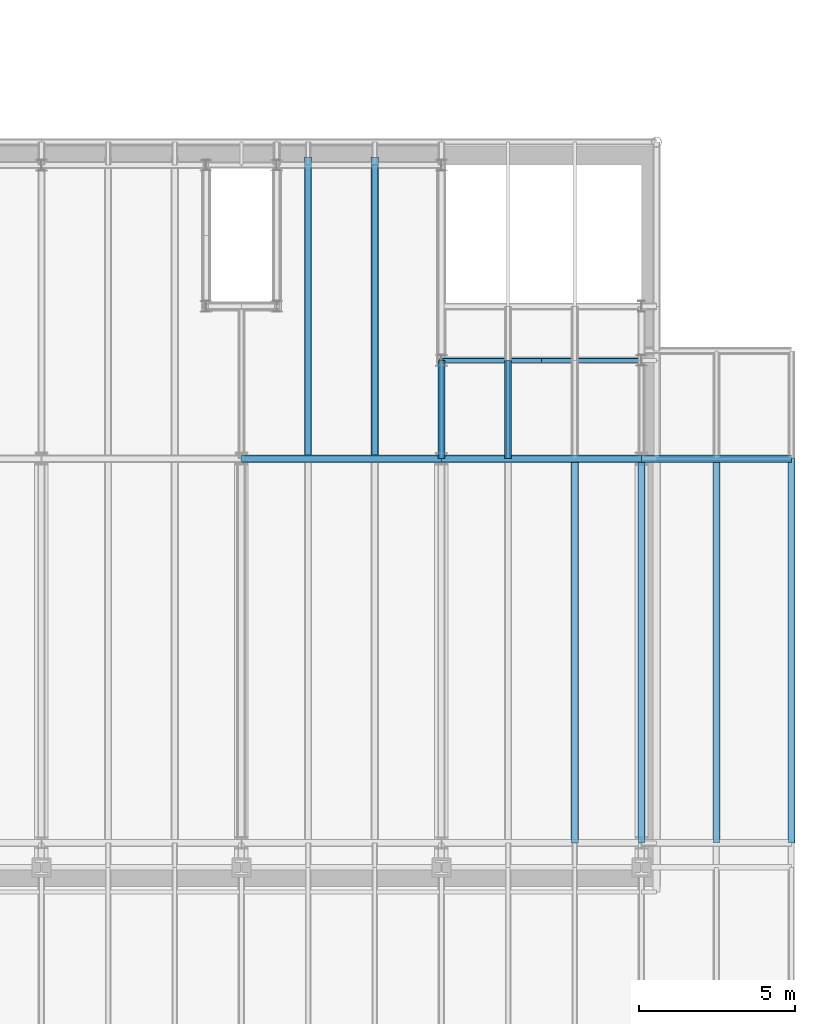
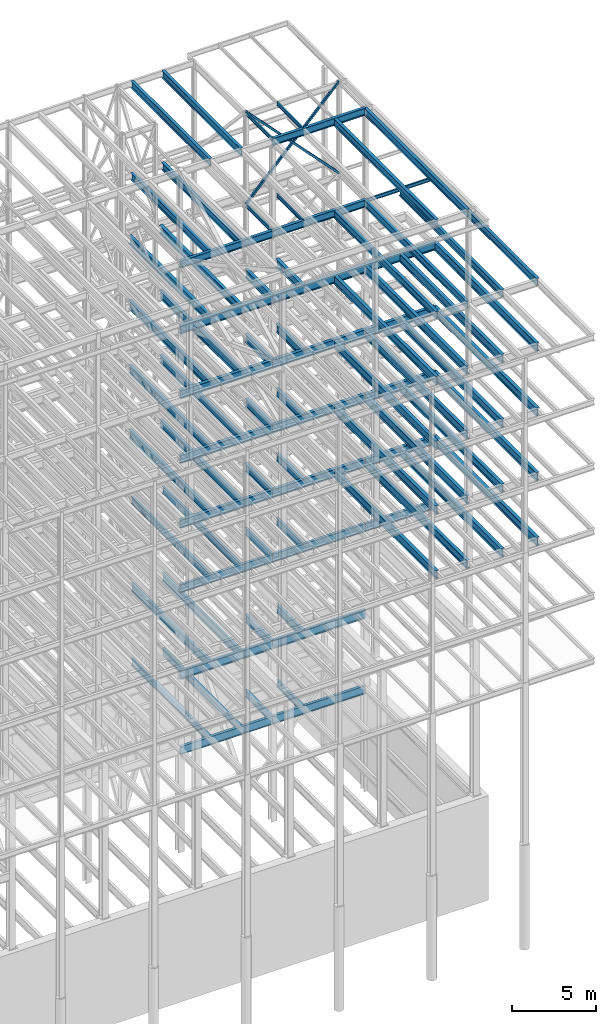
# One storey, part 145 of 150: 83 beams.
"""IFC2X3 building model written with IfcOpenShell, lengths in millimetres."""

from ifc_helpers import new_model, si_unit, frame, origin_with_axes, origin_2d_with_axis, place, context, subcontext, project, spatial, hollow_rectangle, i_section, extrude, material, type_object, element, save


model = new_model("IFC2X3")

# Units and contexts
model_context = context("Model", 3, precision=1e-05, world=origin_with_axes())
body_context = subcontext(model_context, "Body", "Model", "MODEL_VIEW")
ifc_project = project(units=[si_unit("LENGTHUNIT", "METRE", prefix="MILLI"), si_unit("AREAUNIT", "SQUARE_METRE"), si_unit("VOLUMEUNIT", "CUBIC_METRE"), si_unit("MASSUNIT", "GRAM", prefix="KILO"), si_unit("TIMEUNIT", "SECOND"), si_unit("PLANEANGLEUNIT", "RADIAN"), si_unit("SOLIDANGLEUNIT", "STERADIAN"), si_unit("THERMODYNAMICTEMPERATUREUNIT", "DEGREE_CELSIUS"), si_unit("LUMINOUSINTENSITYUNIT", "LUMEN")], contexts=[model_context])

# Site, building, storey
site_placement = place(None, origin_with_axes())
site = spatial("IfcSite", under=ifc_project, at=site_placement, CompositionType="ELEMENT")
building_placement = place(site_placement, origin_with_axes())
building = spatial("IfcBuilding", under=site, at=building_placement, Name="Undefined", CompositionType="ELEMENT")
storey_placement = place(building_placement, origin_with_axes())
storey = spatial("IfcBuildingStorey", under=building, at=storey_placement, Name="Undefined", CompositionType="ELEMENT", Elevation=0.0)

# Beams
ifc_material_1 = material()
beam_type_1 = type_object("IfcBeamType", Name="HSS6X6X3/8", PredefinedType="NOTDEFINED")
for number, where, z_axis, x_axis, name in (
    (1, (88595.2, 25628.6, 59207.4), (0.723355546413844, 0.0, 0.690475744304121), (-0.690475744304122, 0.0, 0.723355546413843), "BEAM"),
    (2, (82194.4, 25628.6, 59207.4), (-0.723355546413844, 0.0, 0.690475744304121), (0.690475744304122, 0.0, 0.723355546413843), "BEAM"),
):
    element("IfcBeam", number, at=place(storey_placement, frame(where, z_axis=z_axis, x_axis=x_axis)), inside=storey, type_object=beam_type_1, material=ifc_material_1, Name=name, ObjectType="HSS6X6X3/8", context=body_context, shape_type="SweptSolid", body=[
        extrude(hollow_rectangle(XDim=152.4, YDim=152.4, WallThickness=9.525, InnerFilletRadius=9.5249, OuterFilletRadius=19.0499, at=origin_2d_with_axis()), frame((9270.13009617449, 3.63797880709171e-12, 0.0), z_axis=(-1.0, 0.0, 0.0), x_axis=(0.0, -1.0, 0.0)), (0.0, 0.0, 1.0), 9270.13009617449),
    ])
ifc_material_2 = material(Name="STEEL/A992")
beam_type_2 = type_object("IfcBeamType", Name="W24X68", PredefinedType="NOTDEFINED")
for number, where, z_axis, x_axis, name in (
    (3, (80060.8, 22479.0, 54181.375), (0.0, 0.0, 1.0), (0.0, 1.0, 0.0), "BEAM"),
    (4, (77927.2, 22479.0, 54181.375), (0.0, 0.0, 1.0), (0.0, 1.0, 0.0), "BEAM"),
):
    element("IfcBeam", number, at=place(storey_placement, frame(where, z_axis=z_axis, x_axis=x_axis)), inside=storey, type_object=beam_type_2, material=ifc_material_2, Name=name, ObjectType="W24X68", context=body_context, shape_type="SweptSolid", body=[
        extrude(i_section(OverallWidth=227.838, OverallDepth=603.25, WebThickness=11.1125, FlangeThickness=14.859, FilletRadius=23.2409, at=origin_2d_with_axis()), frame((9652.0, 0.0, 0.0), z_axis=(-1.0, 0.0, 0.0), x_axis=(0.0, -1.0, 0.0)), (0.0, 0.0, 1.0), 9652.0),
    ])
for number, where, z_axis, x_axis, name in (
    (5, (82194.4, 22479.0, 54181.375), (0.0, 0.0, 1.0), (1.0, 0.0, 0.0), "BEAM"),
    (6, (75793.6, 22479.0, 54181.375), (0.0, 0.0, 1.0), (1.0, 0.0, 0.0), "BEAM"),
):
    element("IfcBeam", number, at=place(storey_placement, frame(where, z_axis=z_axis, x_axis=x_axis)), inside=storey, type_object=beam_type_2, material=ifc_material_2, Name=name, ObjectType="W24X68", context=body_context, shape_type="SweptSolid", body=[
        extrude(i_section(OverallWidth=227.838, OverallDepth=603.25, WebThickness=11.1125, FlangeThickness=14.859, FilletRadius=23.2409, at=origin_2d_with_axis()), frame((6400.80000000001, 0.0, 0.0), z_axis=(-1.0, 0.0, 0.0), x_axis=(0.0, -1.0, 0.0)), (0.0, 0.0, 1.0), 6400.8),
    ])
for number, where, z_axis, x_axis, name in (
    (7, (82194.4, 22479.0, 54181.375), (0.0, 0.0, 1.0), (0.0, 1.0, 0.0), "BEAM"),
    (8, (84328.0, 22479.0, 54181.375), (0.0, 0.0, 1.0), (0.0, 1.0, 0.0), "BEAM"),
):
    element("IfcBeam", number, at=place(storey_placement, frame(where, z_axis=z_axis, x_axis=x_axis)), inside=storey, type_object=beam_type_2, material=ifc_material_2, Name=name, ObjectType="W24X68", context=body_context, shape_type="SweptSolid", body=[
        extrude(i_section(OverallWidth=227.838, OverallDepth=603.25, WebThickness=11.1125, FlangeThickness=14.859, FilletRadius=23.2409, at=origin_2d_with_axis()), frame((3149.59999999999, 0.0, 0.0), z_axis=(-1.0, 0.0, 0.0), x_axis=(0.0, -1.0, 0.0)), (0.0, 0.0, 1.0), 3149.6),
    ])
for number, where, z_axis, x_axis, name in (
    (9, (93395.8, 10185.4, 54181.375), (0.0, 0.0, 1.0), (0.0, 1.0, 0.0), "BEAM"),
    (10, (90995.5, 10185.4, 54181.375), (0.0, 0.0, 1.0), (0.0, 1.0, 0.0), "BEAM"),
):
    element("IfcBeam", number, at=place(storey_placement, frame(where, z_axis=z_axis, x_axis=x_axis)), inside=storey, type_object=beam_type_2, material=ifc_material_2, Name=name, ObjectType="W24X68", context=body_context, shape_type="SweptSolid", body=[
        extrude(i_section(OverallWidth=227.838, OverallDepth=603.25, WebThickness=11.1125, FlangeThickness=14.859, FilletRadius=23.2409, at=origin_2d_with_axis()), frame((12293.6, 0.0, 0.0), z_axis=(-1.0, 0.0, 0.0), x_axis=(0.0, -1.0, 0.0)), (0.0, 0.0, 1.0), 12293.6),
    ])
beam_1_placement = place(storey_placement, frame((88595.2, 22479.0, 54181.375), z_axis=(0.0, 0.0, 1.0), x_axis=(1.0, 0.0, 0.0)))
element("IfcBeam", 11, at=beam_1_placement, inside=storey, type_object=beam_type_2, material=ifc_material_2, Name="BEAM", ObjectType="W24X68", context=body_context, shape_type="SweptSolid", body=[
    extrude(i_section(OverallWidth=227.838, OverallDepth=603.25, WebThickness=11.1125, FlangeThickness=14.859, FilletRadius=23.2409, at=origin_2d_with_axis()), frame((4800.60000000001, 0.0, 0.0), z_axis=(-1.0, 0.0, 0.0), x_axis=(0.0, -1.0, 0.0)), (0.0, 0.0, 1.0), 4800.60000000001),
])
for number, where, z_axis, x_axis, name in (
    (12, (88595.2, 10185.4, 54181.375), (0.0, 0.0, 1.0), (0.0, 1.0, 0.0), "BEAM"),
    (13, (86461.6, 10185.4, 54181.375), (0.0, 0.0, 1.0), (0.0, 1.0, 0.0), "BEAM"),
):
    element("IfcBeam", number, at=place(storey_placement, frame(where, z_axis=z_axis, x_axis=x_axis)), inside=storey, type_object=beam_type_2, material=ifc_material_2, Name=name, ObjectType="W24X68", context=body_context, shape_type="SweptSolid", body=[
        extrude(i_section(OverallWidth=227.838, OverallDepth=603.25, WebThickness=11.1125, FlangeThickness=14.859, FilletRadius=23.2409, at=origin_2d_with_axis()), frame((12293.6, 0.0, 0.0), z_axis=(-1.0, 0.0, 0.0), x_axis=(0.0, -1.0, 0.0)), (0.0, 0.0, 1.0), 12293.6),
    ])
for number, where, z_axis, x_axis, name in (
    (14, (80060.8, 22479.0, 49456.975), (0.0, 0.0, 1.0), (0.0, 1.0, 0.0), "BEAM"),
    (15, (77927.2, 22479.0, 49456.975), (0.0, 0.0, 1.0), (0.0, 1.0, 0.0), "BEAM"),
):
    element("IfcBeam", number, at=place(storey_placement, frame(where, z_axis=z_axis, x_axis=x_axis)), inside=storey, type_object=beam_type_2, material=ifc_material_2, Name=name, ObjectType="W24X68", context=body_context, shape_type="SweptSolid", body=[
        extrude(i_section(OverallWidth=227.838, OverallDepth=603.25, WebThickness=11.1125, FlangeThickness=14.859, FilletRadius=23.2409, at=origin_2d_with_axis()), frame((9652.0, 0.0, 0.0), z_axis=(-1.0, 0.0, 0.0), x_axis=(0.0, -1.0, 0.0)), (0.0, 0.0, 1.0), 9652.0),
    ])
for number, where, z_axis, x_axis, name in (
    (16, (82194.4, 22479.0, 49456.975), (0.0, 0.0, 1.0), (1.0, 0.0, 0.0), "BEAM"),
    (17, (75793.6, 22479.0, 49456.975), (0.0, 0.0, 1.0), (1.0, 0.0, 0.0), "BEAM"),
):
    element("IfcBeam", number, at=place(storey_placement, frame(where, z_axis=z_axis, x_axis=x_axis)), inside=storey, type_object=beam_type_2, material=ifc_material_2, Name=name, ObjectType="W24X68", context=body_context, shape_type="SweptSolid", body=[
        extrude(i_section(OverallWidth=227.838, OverallDepth=603.25, WebThickness=11.1125, FlangeThickness=14.859, FilletRadius=23.2409, at=origin_2d_with_axis()), frame((6400.80000000001, 0.0, 0.0), z_axis=(-1.0, 0.0, 0.0), x_axis=(0.0, -1.0, 0.0)), (0.0, 0.0, 1.0), 6400.8),
    ])
for number, where, z_axis, x_axis, name in (
    (18, (82194.4, 22479.0, 49456.975), (0.0, 0.0, 1.0), (0.0, 1.0, 0.0), "BEAM"),
    (19, (84328.0, 22479.0, 49456.975), (0.0, 0.0, 1.0), (0.0, 1.0, 0.0), "BEAM"),
):
    element("IfcBeam", number, at=place(storey_placement, frame(where, z_axis=z_axis, x_axis=x_axis)), inside=storey, type_object=beam_type_2, material=ifc_material_2, Name=name, ObjectType="W24X68", context=body_context, shape_type="SweptSolid", body=[
        extrude(i_section(OverallWidth=227.838, OverallDepth=603.25, WebThickness=11.1125, FlangeThickness=14.859, FilletRadius=23.2409, at=origin_2d_with_axis()), frame((3149.59999999999, 0.0, 0.0), z_axis=(-1.0, 0.0, 0.0), x_axis=(0.0, -1.0, 0.0)), (0.0, 0.0, 1.0), 3149.6),
    ])
for number, where, z_axis, x_axis, name in (
    (20, (93395.8, 10185.4, 49456.975), (0.0, 0.0, 1.0), (0.0, 1.0, 0.0), "BEAM"),
    (21, (90995.5, 10185.4, 49456.975), (0.0, 0.0, 1.0), (0.0, 1.0, 0.0), "BEAM"),
):
    element("IfcBeam", number, at=place(storey_placement, frame(where, z_axis=z_axis, x_axis=x_axis)), inside=storey, type_object=beam_type_2, material=ifc_material_2, Name=name, ObjectType="W24X68", context=body_context, shape_type="SweptSolid", body=[
        extrude(i_section(OverallWidth=227.838, OverallDepth=603.25, WebThickness=11.1125, FlangeThickness=14.859, FilletRadius=23.2409, at=origin_2d_with_axis()), frame((12293.6, 0.0, 0.0), z_axis=(-1.0, 0.0, 0.0), x_axis=(0.0, -1.0, 0.0)), (0.0, 0.0, 1.0), 12293.6),
    ])
beam_2_placement = place(storey_placement, frame((88595.2, 22479.0, 49456.975), z_axis=(0.0, 0.0, 1.0), x_axis=(1.0, 0.0, 0.0)))
element("IfcBeam", 22, at=beam_2_placement, inside=storey, type_object=beam_type_2, material=ifc_material_2, Name="BEAM", ObjectType="W24X68", context=body_context, shape_type="SweptSolid", body=[
    extrude(i_section(OverallWidth=227.838, OverallDepth=603.25, WebThickness=11.1125, FlangeThickness=14.859, FilletRadius=23.2409, at=origin_2d_with_axis()), frame((4800.60000000001, 0.0, 0.0), z_axis=(-1.0, 0.0, 0.0), x_axis=(0.0, -1.0, 0.0)), (0.0, 0.0, 1.0), 4800.60000000001),
])
for number, where, z_axis, x_axis, name in (
    (23, (88595.2, 10185.4, 49456.975), (0.0, 0.0, 1.0), (0.0, 1.0, 0.0), "BEAM"),
    (24, (86461.6, 10185.4, 49456.975), (0.0, 0.0, 1.0), (0.0, 1.0, 0.0), "BEAM"),
):
    element("IfcBeam", number, at=place(storey_placement, frame(where, z_axis=z_axis, x_axis=x_axis)), inside=storey, type_object=beam_type_2, material=ifc_material_2, Name=name, ObjectType="W24X68", context=body_context, shape_type="SweptSolid", body=[
        extrude(i_section(OverallWidth=227.838, OverallDepth=603.25, WebThickness=11.1125, FlangeThickness=14.859, FilletRadius=23.2409, at=origin_2d_with_axis()), frame((12293.6, 0.0, 0.0), z_axis=(-1.0, 0.0, 0.0), x_axis=(0.0, -1.0, 0.0)), (0.0, 0.0, 1.0), 12293.6),
    ])
for number, where, z_axis, x_axis, name in (
    (25, (80060.8, 22479.0, 44732.575), (0.0, 0.0, 1.0), (0.0, 1.0, 0.0), "BEAM"),
    (26, (77927.2, 22479.0, 44732.575), (0.0, 0.0, 1.0), (0.0, 1.0, 0.0), "BEAM"),
):
    element("IfcBeam", number, at=place(storey_placement, frame(where, z_axis=z_axis, x_axis=x_axis)), inside=storey, type_object=beam_type_2, material=ifc_material_2, Name=name, ObjectType="W24X68", context=body_context, shape_type="SweptSolid", body=[
        extrude(i_section(OverallWidth=227.838, OverallDepth=603.25, WebThickness=11.1125, FlangeThickness=14.859, FilletRadius=23.2409, at=origin_2d_with_axis()), frame((9652.0, 0.0, 0.0), z_axis=(-1.0, 0.0, 0.0), x_axis=(0.0, -1.0, 0.0)), (0.0, 0.0, 1.0), 9652.0),
    ])
for number, where, z_axis, x_axis, name in (
    (27, (82194.4, 22479.0, 44732.575), (0.0, 0.0, 1.0), (1.0, 0.0, 0.0), "BEAM"),
    (28, (75793.6, 22479.0, 44732.575), (0.0, 0.0, 1.0), (1.0, 0.0, 0.0), "BEAM"),
):
    element("IfcBeam", number, at=place(storey_placement, frame(where, z_axis=z_axis, x_axis=x_axis)), inside=storey, type_object=beam_type_2, material=ifc_material_2, Name=name, ObjectType="W24X68", context=body_context, shape_type="SweptSolid", body=[
        extrude(i_section(OverallWidth=227.838, OverallDepth=603.25, WebThickness=11.1125, FlangeThickness=14.859, FilletRadius=23.2409, at=origin_2d_with_axis()), frame((6400.80000000001, 0.0, 0.0), z_axis=(-1.0, 0.0, 0.0), x_axis=(0.0, -1.0, 0.0)), (0.0, 0.0, 1.0), 6400.8),
    ])
for number, where, z_axis, x_axis, name in (
    (29, (82194.4, 22479.0, 44732.575), (0.0, 0.0, 1.0), (0.0, 1.0, 0.0), "BEAM"),
    (30, (84328.0, 22479.0, 44732.575), (0.0, 0.0, 1.0), (0.0, 1.0, 0.0), "BEAM"),
):
    element("IfcBeam", number, at=place(storey_placement, frame(where, z_axis=z_axis, x_axis=x_axis)), inside=storey, type_object=beam_type_2, material=ifc_material_2, Name=name, ObjectType="W24X68", context=body_context, shape_type="SweptSolid", body=[
        extrude(i_section(OverallWidth=227.838, OverallDepth=603.25, WebThickness=11.1125, FlangeThickness=14.859, FilletRadius=23.2409, at=origin_2d_with_axis()), frame((3149.59999999999, 0.0, 0.0), z_axis=(-1.0, 0.0, 0.0), x_axis=(0.0, -1.0, 0.0)), (0.0, 0.0, 1.0), 3149.6),
    ])
for number, where, z_axis, x_axis, name in (
    (31, (93395.8, 10185.4, 44732.575), (0.0, 0.0, 1.0), (0.0, 1.0, 0.0), "BEAM"),
    (32, (90995.5, 10185.4, 44732.575), (0.0, 0.0, 1.0), (0.0, 1.0, 0.0), "BEAM"),
):
    element("IfcBeam", number, at=place(storey_placement, frame(where, z_axis=z_axis, x_axis=x_axis)), inside=storey, type_object=beam_type_2, material=ifc_material_2, Name=name, ObjectType="W24X68", context=body_context, shape_type="SweptSolid", body=[
        extrude(i_section(OverallWidth=227.838, OverallDepth=603.25, WebThickness=11.1125, FlangeThickness=14.859, FilletRadius=23.2409, at=origin_2d_with_axis()), frame((12293.6, 0.0, 0.0), z_axis=(-1.0, 0.0, 0.0), x_axis=(0.0, -1.0, 0.0)), (0.0, 0.0, 1.0), 12293.6),
    ])
beam_3_placement = place(storey_placement, frame((88595.2, 22479.0, 44732.575), z_axis=(0.0, 0.0, 1.0), x_axis=(1.0, 0.0, 0.0)))
element("IfcBeam", 33, at=beam_3_placement, inside=storey, type_object=beam_type_2, material=ifc_material_2, Name="BEAM", ObjectType="W24X68", context=body_context, shape_type="SweptSolid", body=[
    extrude(i_section(OverallWidth=227.838, OverallDepth=603.25, WebThickness=11.1125, FlangeThickness=14.859, FilletRadius=23.2409, at=origin_2d_with_axis()), frame((4800.60000000001, 0.0, 0.0), z_axis=(-1.0, 0.0, 0.0), x_axis=(0.0, -1.0, 0.0)), (0.0, 0.0, 1.0), 4800.60000000001),
])
for number, where, z_axis, x_axis, name in (
    (34, (88595.2, 10185.4, 44732.575), (0.0, 0.0, 1.0), (0.0, 1.0, 0.0), "BEAM"),
    (35, (86461.6, 10185.4, 44732.575), (0.0, 0.0, 1.0), (0.0, 1.0, 0.0), "BEAM"),
):
    element("IfcBeam", number, at=place(storey_placement, frame(where, z_axis=z_axis, x_axis=x_axis)), inside=storey, type_object=beam_type_2, material=ifc_material_2, Name=name, ObjectType="W24X68", context=body_context, shape_type="SweptSolid", body=[
        extrude(i_section(OverallWidth=227.838, OverallDepth=603.25, WebThickness=11.1125, FlangeThickness=14.859, FilletRadius=23.2409, at=origin_2d_with_axis()), frame((12293.6, 0.0, 0.0), z_axis=(-1.0, 0.0, 0.0), x_axis=(0.0, -1.0, 0.0)), (0.0, 0.0, 1.0), 12293.6),
    ])
for number, where, z_axis, x_axis, name in (
    (36, (80060.8, 22479.0, 40008.175), (0.0, 0.0, 1.0), (0.0, 1.0, 0.0), "BEAM"),
    (37, (77927.2, 22479.0, 40008.175), (0.0, 0.0, 1.0), (0.0, 1.0, 0.0), "BEAM"),
):
    element("IfcBeam", number, at=place(storey_placement, frame(where, z_axis=z_axis, x_axis=x_axis)), inside=storey, type_object=beam_type_2, material=ifc_material_2, Name=name, ObjectType="W24X68", context=body_context, shape_type="SweptSolid", body=[
        extrude(i_section(OverallWidth=227.838, OverallDepth=603.25, WebThickness=11.1125, FlangeThickness=14.859, FilletRadius=23.2409, at=origin_2d_with_axis()), frame((9652.0, 0.0, 0.0), z_axis=(-1.0, 0.0, 0.0), x_axis=(0.0, -1.0, 0.0)), (0.0, 0.0, 1.0), 9652.0),
    ])
for number, where, z_axis, x_axis, name in (
    (38, (82194.4, 22479.0, 40008.175), (0.0, 0.0, 1.0), (1.0, 0.0, 0.0), "BEAM"),
    (39, (75793.6, 22479.0, 40008.175), (0.0, 0.0, 1.0), (1.0, 0.0, 0.0), "BEAM"),
):
    element("IfcBeam", number, at=place(storey_placement, frame(where, z_axis=z_axis, x_axis=x_axis)), inside=storey, type_object=beam_type_2, material=ifc_material_2, Name=name, ObjectType="W24X68", context=body_context, shape_type="SweptSolid", body=[
        extrude(i_section(OverallWidth=227.838, OverallDepth=603.25, WebThickness=11.1125, FlangeThickness=14.859, FilletRadius=23.2409, at=origin_2d_with_axis()), frame((6400.80000000001, 0.0, 0.0), z_axis=(-1.0, 0.0, 0.0), x_axis=(0.0, -1.0, 0.0)), (0.0, 0.0, 1.0), 6400.8),
    ])
for number, where, z_axis, x_axis, name in (
    (40, (82194.4, 22479.0, 40008.175), (0.0, 0.0, 1.0), (0.0, 1.0, 0.0), "BEAM"),
    (41, (84328.0, 22479.0, 40008.175), (0.0, 0.0, 1.0), (0.0, 1.0, 0.0), "BEAM"),
):
    element("IfcBeam", number, at=place(storey_placement, frame(where, z_axis=z_axis, x_axis=x_axis)), inside=storey, type_object=beam_type_2, material=ifc_material_2, Name=name, ObjectType="W24X68", context=body_context, shape_type="SweptSolid", body=[
        extrude(i_section(OverallWidth=227.838, OverallDepth=603.25, WebThickness=11.1125, FlangeThickness=14.859, FilletRadius=23.2409, at=origin_2d_with_axis()), frame((3149.59999999999, 0.0, 0.0), z_axis=(-1.0, 0.0, 0.0), x_axis=(0.0, -1.0, 0.0)), (0.0, 0.0, 1.0), 3149.6),
    ])
for number, where, z_axis, x_axis, name in (
    (42, (93395.8, 10185.4, 40008.175), (0.0, 0.0, 1.0), (0.0, 1.0, 0.0), "BEAM"),
    (43, (90995.5, 10185.4, 40008.175), (0.0, 0.0, 1.0), (0.0, 1.0, 0.0), "BEAM"),
):
    element("IfcBeam", number, at=place(storey_placement, frame(where, z_axis=z_axis, x_axis=x_axis)), inside=storey, type_object=beam_type_2, material=ifc_material_2, Name=name, ObjectType="W24X68", context=body_context, shape_type="SweptSolid", body=[
        extrude(i_section(OverallWidth=227.838, OverallDepth=603.25, WebThickness=11.1125, FlangeThickness=14.859, FilletRadius=23.2409, at=origin_2d_with_axis()), frame((12293.6, 0.0, 0.0), z_axis=(-1.0, 0.0, 0.0), x_axis=(0.0, -1.0, 0.0)), (0.0, 0.0, 1.0), 12293.6),
    ])
beam_4_placement = place(storey_placement, frame((88595.2, 22479.0, 40008.175), z_axis=(0.0, 0.0, 1.0), x_axis=(1.0, 0.0, 0.0)))
element("IfcBeam", 44, at=beam_4_placement, inside=storey, type_object=beam_type_2, material=ifc_material_2, Name="BEAM", ObjectType="W24X68", context=body_context, shape_type="SweptSolid", body=[
    extrude(i_section(OverallWidth=227.838, OverallDepth=603.25, WebThickness=11.1125, FlangeThickness=14.859, FilletRadius=23.2409, at=origin_2d_with_axis()), frame((4800.60000000001, 0.0, 0.0), z_axis=(-1.0, 0.0, 0.0), x_axis=(0.0, -1.0, 0.0)), (0.0, 0.0, 1.0), 4800.60000000001),
])
for number, where, z_axis, x_axis, name in (
    (45, (88595.2, 10185.4, 40008.175), (0.0, 0.0, 1.0), (0.0, 1.0, 0.0), "BEAM"),
    (46, (86461.6, 10185.4, 40008.175), (0.0, 0.0, 1.0), (0.0, 1.0, 0.0), "BEAM"),
):
    element("IfcBeam", number, at=place(storey_placement, frame(where, z_axis=z_axis, x_axis=x_axis)), inside=storey, type_object=beam_type_2, material=ifc_material_2, Name=name, ObjectType="W24X68", context=body_context, shape_type="SweptSolid", body=[
        extrude(i_section(OverallWidth=227.838, OverallDepth=603.25, WebThickness=11.1125, FlangeThickness=14.859, FilletRadius=23.2409, at=origin_2d_with_axis()), frame((12293.6, 0.0, 0.0), z_axis=(-1.0, 0.0, 0.0), x_axis=(0.0, -1.0, 0.0)), (0.0, 0.0, 1.0), 12293.6),
    ])
for number, where, z_axis, x_axis, name in (
    (47, (82194.4, 22479.0, 28984.575), (0.0, 0.0, 1.0), (1.0, 0.0, 0.0), "BEAM"),
    (48, (75793.6, 22479.0, 28984.575), (0.0, 0.0, 1.0), (1.0, 0.0, 0.0), "BEAM"),
):
    element("IfcBeam", number, at=place(storey_placement, frame(where, z_axis=z_axis, x_axis=x_axis)), inside=storey, type_object=beam_type_2, material=ifc_material_2, Name=name, ObjectType="W24X68", context=body_context, shape_type="SweptSolid", body=[
        extrude(i_section(OverallWidth=227.838, OverallDepth=603.25, WebThickness=11.1125, FlangeThickness=14.859, FilletRadius=23.2409, at=origin_2d_with_axis()), frame((6400.80000000001, 0.0, 0.0), z_axis=(-1.0, 0.0, 0.0), x_axis=(0.0, -1.0, 0.0)), (0.0, 0.0, 1.0), 6400.8),
    ])
beam_type_3 = type_object("IfcBeamType", Name="W21X55", PredefinedType="NOTDEFINED")
for number, where, z_axis, x_axis, name in (
    (49, (80060.8, 22479.0, 65649.475), (0.0, 0.0, 1.0), (0.0, 1.0, 0.0), "BEAM"),
    (50, (77927.2, 22479.0, 65649.475), (0.0, 0.0, 1.0), (0.0, 1.0, 0.0), "BEAM"),
):
    element("IfcBeam", number, at=place(storey_placement, frame(where, z_axis=z_axis, x_axis=x_axis)), inside=storey, type_object=beam_type_3, material=ifc_material_2, Name=name, ObjectType="W21X55", context=body_context, shape_type="SweptSolid", body=[
        extrude(i_section(OverallWidth=208.788, OverallDepth=527.05, WebThickness=9.5, FlangeThickness=13.2588, FilletRadius=16.8624, at=origin_2d_with_axis()), frame((9398.0, 0.0, 0.0), z_axis=(-1.0, 0.0, 0.0), x_axis=(0.0, -1.0, 0.0)), (0.0, 0.0, 1.0), 9398.0),
    ])
beam_5_placement = place(storey_placement, frame((88595.2, 10185.4, 65649.475), z_axis=(0.0, 0.0, 1.0), x_axis=(0.0, 1.0, 0.0)))
element("IfcBeam", 51, at=beam_5_placement, inside=storey, type_object=beam_type_3, material=ifc_material_2, Name="BEAM", ObjectType="W21X55", context=body_context, shape_type="SweptSolid", body=[
    extrude(i_section(OverallWidth=208.788, OverallDepth=527.05, WebThickness=9.5, FlangeThickness=13.2588, FilletRadius=16.8624, at=origin_2d_with_axis()), frame((12293.6, 0.0, 0.0), z_axis=(-1.0, 0.0, 0.0), x_axis=(0.0, -1.0, 0.0)), (0.0, 0.0, 1.0), 12293.6),
])
beam_6_placement = place(storey_placement, frame((82194.4, 22479.0, 65649.475), z_axis=(0.0, 0.0, 1.0), x_axis=(1.0, 0.0, 0.0)))
element("IfcBeam", 52, at=beam_6_placement, inside=storey, type_object=beam_type_3, material=ifc_material_2, Name="BEAM", ObjectType="W21X55", context=body_context, shape_type="SweptSolid", body=[
    extrude(i_section(OverallWidth=208.788, OverallDepth=527.05, WebThickness=9.5, FlangeThickness=13.2588, FilletRadius=16.8624, at=origin_2d_with_axis()), frame((6400.80000000001, 0.0, 0.0), z_axis=(-1.0, 0.0, 0.0), x_axis=(0.0, -1.0, 0.0)), (0.0, 0.0, 1.0), 6400.8),
])
for number, where, z_axis, x_axis, name in (
    (53, (86461.6, 10185.4, 65649.475), (0.0, 0.0, 1.0), (0.0, 1.0, 0.0), "BEAM"),
    (54, (93395.8, 10185.4, 58943.875), (0.0, 0.0, 1.0), (0.0, 1.0, 0.0), "BEAM"),
    (55, (90995.5, 10185.4, 58943.875), (0.0, 0.0, 1.0), (0.0, 1.0, 0.0), "BEAM"),
):
    element("IfcBeam", number, at=place(storey_placement, frame(where, z_axis=z_axis, x_axis=x_axis)), inside=storey, type_object=beam_type_3, material=ifc_material_2, Name=name, ObjectType="W21X55", context=body_context, shape_type="SweptSolid", body=[
        extrude(i_section(OverallWidth=208.788, OverallDepth=527.05, WebThickness=9.5, FlangeThickness=13.2588, FilletRadius=16.8624, at=origin_2d_with_axis()), frame((12293.6, 0.0, 0.0), z_axis=(-1.0, 0.0, 0.0), x_axis=(0.0, -1.0, 0.0)), (0.0, 0.0, 1.0), 12293.6),
    ])
for number, where, z_axis, x_axis, name in (
    (56, (80060.8, 22479.0, 58943.875), (0.0, 0.0, 1.0), (0.0, 1.0, 0.0), "BEAM"),
    (57, (77927.2, 22479.0, 58943.875), (0.0, 0.0, 1.0), (0.0, 1.0, 0.0), "BEAM"),
):
    element("IfcBeam", number, at=place(storey_placement, frame(where, z_axis=z_axis, x_axis=x_axis)), inside=storey, type_object=beam_type_3, material=ifc_material_2, Name=name, ObjectType="W21X55", context=body_context, shape_type="SweptSolid", body=[
        extrude(i_section(OverallWidth=208.788, OverallDepth=527.05, WebThickness=9.5, FlangeThickness=13.2588, FilletRadius=16.8624, at=origin_2d_with_axis()), frame((9398.0, 0.0, 0.0), z_axis=(-1.0, 0.0, 0.0), x_axis=(0.0, -1.0, 0.0)), (0.0, 0.0, 1.0), 9398.0),
    ])
beam_7_placement = place(storey_placement, frame((88595.2, 10185.4, 58943.875), z_axis=(0.0, 0.0, 1.0), x_axis=(0.0, 1.0, 0.0)))
element("IfcBeam", 58, at=beam_7_placement, inside=storey, type_object=beam_type_3, material=ifc_material_2, Name="BEAM", ObjectType="W21X55", context=body_context, shape_type="SweptSolid", body=[
    extrude(i_section(OverallWidth=208.788, OverallDepth=527.05, WebThickness=9.5, FlangeThickness=13.2588, FilletRadius=16.8624, at=origin_2d_with_axis()), frame((12293.6, 0.0, 0.0), z_axis=(-1.0, 0.0, 0.0), x_axis=(0.0, -1.0, 0.0)), (0.0, 0.0, 1.0), 12293.6),
])
beam_8_placement = place(storey_placement, frame((82194.4, 22479.0, 58943.875), z_axis=(0.0, 0.0, 1.0), x_axis=(1.0, 0.0, 0.0)))
element("IfcBeam", 59, at=beam_8_placement, inside=storey, type_object=beam_type_3, material=ifc_material_2, Name="BEAM", ObjectType="W21X55", context=body_context, shape_type="SweptSolid", body=[
    extrude(i_section(OverallWidth=208.788, OverallDepth=527.05, WebThickness=9.5, FlangeThickness=13.2588, FilletRadius=16.8624, at=origin_2d_with_axis()), frame((6400.80000000001, 0.0, 0.0), z_axis=(-1.0, 0.0, 0.0), x_axis=(0.0, -1.0, 0.0)), (0.0, 0.0, 1.0), 6400.8),
])
beam_9_placement = place(storey_placement, frame((86461.6, 10185.4, 58943.875), z_axis=(0.0, 0.0, 1.0), x_axis=(0.0, 1.0, 0.0)))
element("IfcBeam", 60, at=beam_9_placement, inside=storey, type_object=beam_type_3, material=ifc_material_2, Name="BEAM", ObjectType="W21X55", context=body_context, shape_type="SweptSolid", body=[
    extrude(i_section(OverallWidth=208.788, OverallDepth=527.05, WebThickness=9.5, FlangeThickness=13.2588, FilletRadius=16.8624, at=origin_2d_with_axis()), frame((12293.6, 0.0, 0.0), z_axis=(-1.0, 0.0, 0.0), x_axis=(0.0, -1.0, 0.0)), (0.0, 0.0, 1.0), 12293.6),
])
beam_10_placement = place(storey_placement, frame((75793.6, 22479.0, 58943.875), z_axis=(0.0, 0.0, 1.0), x_axis=(1.0, 0.0, 0.0)))
element("IfcBeam", 61, at=beam_10_placement, inside=storey, type_object=beam_type_3, material=ifc_material_2, Name="BEAM", ObjectType="W21X55", context=body_context, shape_type="SweptSolid", body=[
    extrude(i_section(OverallWidth=208.788, OverallDepth=527.05, WebThickness=9.5, FlangeThickness=13.2588, FilletRadius=16.8624, at=origin_2d_with_axis()), frame((6400.80000000001, 0.0, 0.0), z_axis=(-1.0, 0.0, 0.0), x_axis=(0.0, -1.0, 0.0)), (0.0, 0.0, 1.0), 6400.8),
])
beam_type_4 = type_object("IfcBeamType", Name="W10X15", PredefinedType="NOTDEFINED")
beam_11_placement = place(storey_placement, frame((88595.2, 22479.0, 59080.4), z_axis=(0.0, 0.0, 1.0), x_axis=(1.0, 0.0, 0.0)))
element("IfcBeam", 62, at=beam_11_placement, inside=storey, type_object=beam_type_4, material=ifc_material_2, Name="BEAM", ObjectType="W10X15", context=body_context, shape_type="SweptSolid", body=[
    extrude(i_section(OverallWidth=101.6, OverallDepth=254.0, WebThickness=6.3499, FlangeThickness=6.858, FilletRadius=13.7795, at=origin_2d_with_axis()), frame((4800.60000000001, 0.0, 0.0), z_axis=(-1.0, 0.0, 0.0), x_axis=(0.0, -1.0, 0.0)), (0.0, 0.0, 1.0), 4800.60000000001),
])
for number, where, z_axis, x_axis, name in (
    (63, (84328.0, 22479.0, 65786.0), (0.0, 0.0, 1.0), (0.0, 1.0, 0.0), "BEAM"),
    (64, (82194.4, 22479.0, 65786.0), (0.0, 0.0, 1.0), (0.0, 1.0, 0.0), "BEAM"),
    (65, (84328.0, 22479.0, 59080.4), (0.0, 0.0, 1.0), (0.0, 1.0, 0.0), "BEAM"),
    (66, (82194.4, 22479.0, 59080.4), (0.0, 0.0, 1.0), (0.0, 1.0, 0.0), "BEAM"),
):
    element("IfcBeam", number, at=place(storey_placement, frame(where, z_axis=z_axis, x_axis=x_axis)), inside=storey, type_object=beam_type_4, material=ifc_material_2, Name=name, ObjectType="W10X15", context=body_context, shape_type="SweptSolid", body=[
        extrude(i_section(OverallWidth=101.6, OverallDepth=254.0, WebThickness=6.3499, FlangeThickness=6.858, FilletRadius=13.7795, at=origin_2d_with_axis()), frame((3149.59999999999, 0.0, 0.0), z_axis=(-1.0, 0.0, 0.0), x_axis=(0.0, -1.0, 0.0)), (0.0, 0.0, 1.0), 3149.6),
    ])
beam_type_5 = type_object("IfcBeamType", Name="W24X55", PredefinedType="NOTDEFINED")
beam_12_placement = place(storey_placement, frame((84328.0, 22479.0, 28986.1625), z_axis=(0.0, 0.0, 1.0), x_axis=(0.0, 1.0, 0.0)))
element("IfcBeam", 67, at=beam_12_placement, inside=storey, type_object=beam_type_5, material=ifc_material_2, Name="BEAM", ObjectType="W24X55", context=body_context, shape_type="SweptSolid", body=[
    extrude(i_section(OverallWidth=178.054, OverallDepth=600.075, WebThickness=9.5249, FlangeThickness=12.827, FilletRadius=23.6854, at=origin_2d_with_axis()), frame((3149.59968503999, 0.0, 0.0), z_axis=(-1.0, 0.0, 0.0), x_axis=(0.0, -1.0, 0.0)), (0.0, 0.0, 1.0), 3149.59968503999),
])
beam_13_placement = place(storey_placement, frame((82194.4, 22479.0, 28986.1625), z_axis=(0.0, 0.0, 1.0), x_axis=(0.0, 1.0, 0.0)))
element("IfcBeam", 68, at=beam_13_placement, inside=storey, type_object=beam_type_5, material=ifc_material_2, Name="BEAM", ObjectType="W24X55", context=body_context, shape_type="SweptSolid", body=[
    extrude(i_section(OverallWidth=178.054, OverallDepth=600.075, WebThickness=9.5249, FlangeThickness=12.827, FilletRadius=23.6854, at=origin_2d_with_axis()), frame((3149.59999999999, 0.0, 0.0), z_axis=(-1.0, 0.0, 0.0), x_axis=(0.0, -1.0, 0.0)), (0.0, 0.0, 1.0), 3149.59999999999),
])
for number, where, z_axis, x_axis, name in (
    (69, (77927.2, 22479.0, 28986.1625), (0.0, 0.0, 1.0), (0.0, 1.0, 0.0), "BEAM"),
    (70, (80060.8, 22479.0, 28986.1625), (0.0, 0.0, 1.0), (0.0, 1.0, 0.0), "BEAM"),
):
    element("IfcBeam", number, at=place(storey_placement, frame(where, z_axis=z_axis, x_axis=x_axis)), inside=storey, type_object=beam_type_5, material=ifc_material_2, Name=name, ObjectType="W24X55", context=body_context, shape_type="SweptSolid", body=[
        extrude(i_section(OverallWidth=178.054, OverallDepth=600.075, WebThickness=9.5249, FlangeThickness=12.827, FilletRadius=23.6854, at=origin_2d_with_axis()), frame((9398.0, 0.0, 0.0), z_axis=(-1.0, 0.0, 0.0), x_axis=(0.0, -1.0, 0.0)), (0.0, 0.0, 1.0), 9398.00000000001),
    ])
beam_type_6 = type_object("IfcBeamType", Name="W21X44", PredefinedType="NOTDEFINED")
beam_14_placement = place(storey_placement, frame((82194.4, 22479.0, 35323.4625), z_axis=(0.0, 0.0, 1.0), x_axis=(0.0, 1.0, 0.0)))
element("IfcBeam", 71, at=beam_14_placement, inside=storey, type_object=beam_type_6, material=ifc_material_2, Name="BEAM", ObjectType="W21X44", context=body_context, shape_type="SweptSolid", body=[
    extrude(i_section(OverallWidth=165.1, OverallDepth=523.875, WebThickness=9.5249, FlangeThickness=11.43, FilletRadius=17.145, at=origin_2d_with_axis()), frame((3149.59999999999, 0.0, 0.0), z_axis=(-1.0, 0.0, 0.0), x_axis=(0.0, -1.0, 0.0)), (0.0, 0.0, 1.0), 3149.59999999999),
])
for number, where, z_axis, x_axis, name in (
    (72, (80060.79935992, 22479.0, 35323.4625), (0.0, 0.0, 1.0), (0.0, 1.0, 0.0), "BEAM"),
    (73, (77927.19935992, 22479.0, 35323.4625), (0.0, 0.0, 1.0), (0.0, 1.0, 0.0), "BEAM"),
):
    element("IfcBeam", number, at=place(storey_placement, frame(where, z_axis=z_axis, x_axis=x_axis)), inside=storey, type_object=beam_type_6, material=ifc_material_2, Name=name, ObjectType="W21X44", context=body_context, shape_type="SweptSolid", body=[
        extrude(i_section(OverallWidth=165.1, OverallDepth=523.875, WebThickness=9.5249, FlangeThickness=11.43, FilletRadius=17.145, at=origin_2d_with_axis()), frame((9398.0, 0.0, 0.0), z_axis=(-1.0, 0.0, 0.0), x_axis=(0.0, -1.0, 0.0)), (0.0, 0.0, 1.0), 9398.00000000001),
    ])
beam_15_placement = place(storey_placement, frame((84327.99935992, 22479.0, 35323.4625), z_axis=(0.0, 0.0, 1.0), x_axis=(0.0, 1.0, 0.0)))
element("IfcBeam", 74, at=beam_15_placement, inside=storey, type_object=beam_type_6, material=ifc_material_2, Name="BEAM", ObjectType="W21X44", context=body_context, shape_type="SweptSolid", body=[
    extrude(i_section(OverallWidth=165.1, OverallDepth=523.875, WebThickness=9.5249, FlangeThickness=11.43, FilletRadius=17.145, at=origin_2d_with_axis()), frame((3149.59999999999, 0.0, 0.0), z_axis=(-1.0, 0.0, 0.0), x_axis=(0.0, -1.0, 0.0)), (0.0, 0.0, 1.0), 3149.59999999999),
])
beam_16_placement = place(storey_placement, frame((84328.0, 22479.0, 23512.4625), z_axis=(0.0, 0.0, 1.0), x_axis=(0.0, 1.0, 0.0)))
element("IfcBeam", 75, at=beam_16_placement, inside=storey, type_object=beam_type_6, material=ifc_material_2, Name="BEAM", ObjectType="W21X44", context=body_context, shape_type="SweptSolid", body=[
    extrude(i_section(OverallWidth=165.1, OverallDepth=523.875, WebThickness=9.5249, FlangeThickness=11.43, FilletRadius=17.145, at=origin_2d_with_axis()), frame((3149.59999999999, 0.0, 0.0), z_axis=(-1.0, 0.0, 0.0), x_axis=(0.0, -1.0, 0.0)), (0.0, 0.0, 1.0), 3149.6),
])
beam_17_placement = place(storey_placement, frame((82194.4, 22479.0, 23512.4625), z_axis=(0.0, 0.0, 1.0), x_axis=(0.0, 1.0, 0.0)))
element("IfcBeam", 76, at=beam_17_placement, inside=storey, type_object=beam_type_6, material=ifc_material_2, Name="BEAM", ObjectType="W21X44", context=body_context, shape_type="SweptSolid", body=[
    extrude(i_section(OverallWidth=165.1, OverallDepth=523.875, WebThickness=9.5249, FlangeThickness=11.43, FilletRadius=17.145, at=origin_2d_with_axis()), frame((3149.59968503999, 0.0, 0.0), z_axis=(-1.0, 0.0, 0.0), x_axis=(0.0, -1.0, 0.0)), (0.0, 0.0, 1.0), 3149.59968503999),
])
for number, where, z_axis, x_axis, name in (
    (77, (80060.8, 22479.0, 23512.4625), (0.0, 0.0, 1.0), (0.0, 1.0, 0.0), "BEAM"),
    (78, (77927.2, 22479.0, 23512.4625), (0.0, 0.0, 1.0), (0.0, 1.0, 0.0), "BEAM"),
):
    element("IfcBeam", number, at=place(storey_placement, frame(where, z_axis=z_axis, x_axis=x_axis)), inside=storey, type_object=beam_type_6, material=ifc_material_2, Name=name, ObjectType="W21X44", context=body_context, shape_type="SweptSolid", body=[
        extrude(i_section(OverallWidth=165.1, OverallDepth=523.875, WebThickness=9.5249, FlangeThickness=11.43, FilletRadius=17.145, at=origin_2d_with_axis()), frame((9398.0, 0.0, 0.0), z_axis=(-1.0, 0.0, 0.0), x_axis=(0.0, -1.0, 0.0)), (0.0, 0.0, 1.0), 9398.00000000001),
    ])
beam_type_7 = type_object("IfcBeamType", Name="W24X62", PredefinedType="NOTDEFINED")
beam_18_placement = place(storey_placement, frame((88595.2, 22479.0, 35283.775), z_axis=(0.0, 0.0, 1.0), x_axis=(1.0, 0.0, 0.0)))
element("IfcBeam", 79, at=beam_18_placement, inside=storey, type_object=beam_type_7, material=ifc_material_2, Name="BEAM", ObjectType="W24X62", context=body_context, shape_type="SweptSolid", body=[
    extrude(i_section(OverallWidth=177.8, OverallDepth=603.25, WebThickness=11.1125, FlangeThickness=14.986, FilletRadius=23.114, at=origin_2d_with_axis()), frame((4800.60000000001, 0.0, 0.0), z_axis=(-1.0, 0.0, 0.0), x_axis=(0.0, -1.0, 0.0)), (0.0, 0.0, 1.0), 4800.60000000001),
])
for number, where, z_axis, x_axis, name in (
    (80, (82194.4, 22479.0, 35283.775), (0.0, 0.0, 1.0), (1.0, 0.0, 0.0), "BEAM"),
    (81, (75793.6, 22479.0, 35283.775), (0.0, 0.0, 1.0), (1.0, 0.0, 0.0), "BEAM"),
    (82, (82194.4, 22479.0, 23472.775), (0.0, 0.0, 1.0), (1.0, 0.0, 0.0), "BEAM"),
    (83, (75793.6, 22479.0, 23472.775), (0.0, 0.0, 1.0), (1.0, 0.0, 0.0), "BEAM"),
):
    element("IfcBeam", number, at=place(storey_placement, frame(where, z_axis=z_axis, x_axis=x_axis)), inside=storey, type_object=beam_type_7, material=ifc_material_2, Name=name, ObjectType="W24X62", context=body_context, shape_type="SweptSolid", body=[
        extrude(i_section(OverallWidth=177.8, OverallDepth=603.25, WebThickness=11.1125, FlangeThickness=14.986, FilletRadius=23.114, at=origin_2d_with_axis()), frame((6400.80000000001, 0.0, 0.0), z_axis=(-1.0, 0.0, 0.0), x_axis=(0.0, -1.0, 0.0)), (0.0, 0.0, 1.0), 6400.8),
    ])

save(model, "model.ifc")
